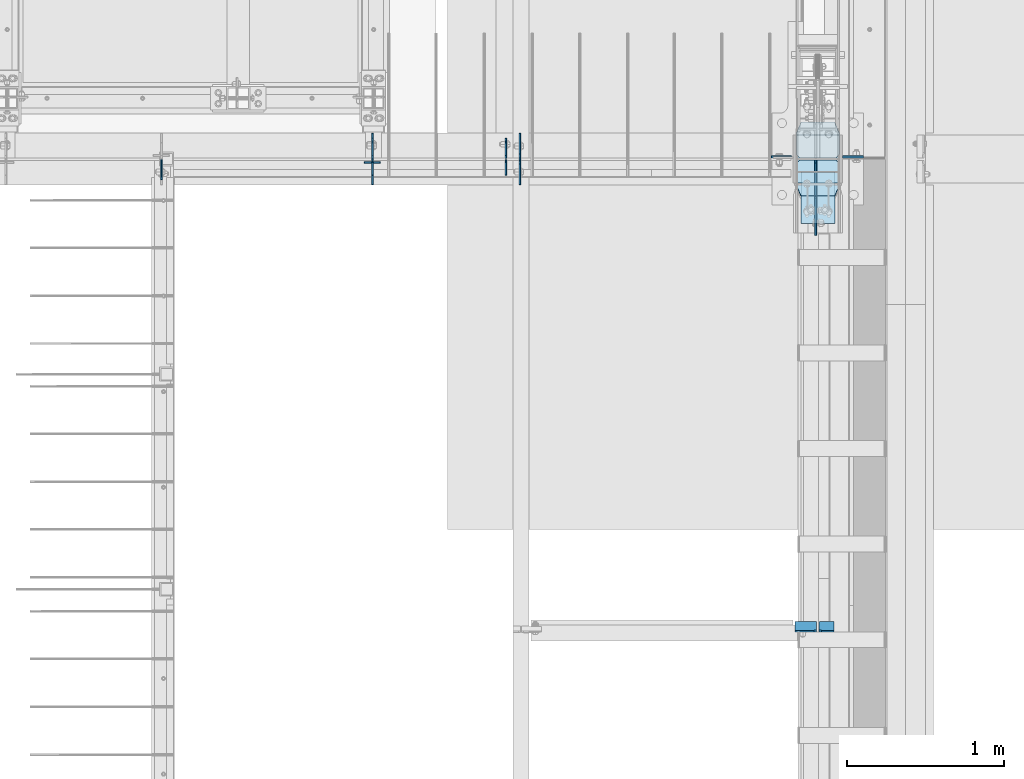
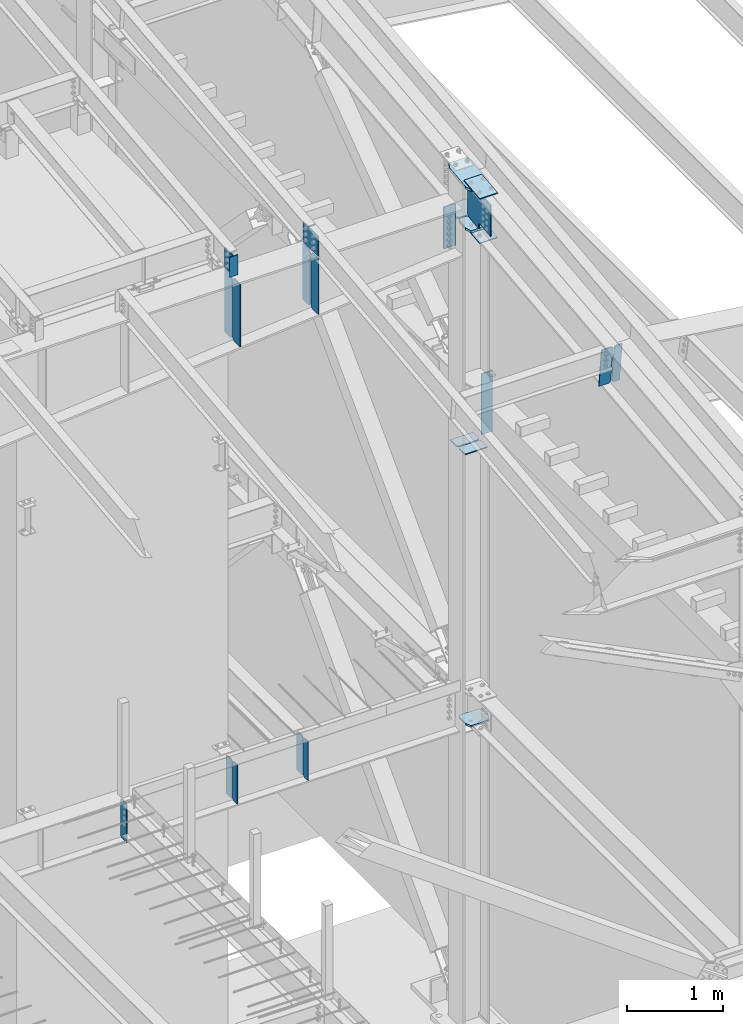
# One storey, part 1006 of 1179: 25 plates, 4 elements without a shape of their own.
"""IFC2X3 building model written with IfcOpenShell, lengths in millimetres."""

from ifc_helpers import new_model, si_unit, frame, origin_with_axes, place, context, subcontext, project, spatial, faceted_brep, material, type_object, element, aggregate, save


model = new_model("IFC2X3")

# Units and contexts
model_context = context("Model", 3, precision=1e-05, world=origin_with_axes())
body_context = subcontext(model_context, "Body", "Model", "MODEL_VIEW")
ifc_project = project(units=[si_unit("LENGTHUNIT", "METRE", prefix="MILLI"), si_unit("AREAUNIT", "SQUARE_METRE"), si_unit("VOLUMEUNIT", "CUBIC_METRE"), si_unit("MASSUNIT", "GRAM", prefix="KILO"), si_unit("TIMEUNIT", "SECOND"), si_unit("PLANEANGLEUNIT", "RADIAN"), si_unit("SOLIDANGLEUNIT", "STERADIAN"), si_unit("THERMODYNAMICTEMPERATUREUNIT", "DEGREE_CELSIUS"), si_unit("LUMINOUSINTENSITYUNIT", "LUMEN")], contexts=[model_context])

# Site, building, storey
site_placement = place(None, origin_with_axes())
site = spatial("IfcSite", under=ifc_project, at=site_placement, CompositionType="ELEMENT")
building_placement = place(site_placement, origin_with_axes())
building = spatial("IfcBuilding", under=site, at=building_placement, Name="Undefined", CompositionType="ELEMENT")
storey_placement = place(building_placement, origin_with_axes())
storey = spatial("IfcBuildingStorey", under=building, at=storey_placement, Name="Undefined", CompositionType="ELEMENT", Elevation=0.0)

# Assembly, plates
assembly_1_placement = place(storey_placement, origin_with_axes())
assembly_1 = element("IfcElementAssembly", 1, at=assembly_1_placement, inside=storey, Name="BEAM", AssemblyPlace="NOTDEFINED", PredefinedType="RIGID_FRAME")
ifc_material_1 = material(Name="STEEL/A36")
plate_type_1 = type_object("IfcPlateType", PredefinedType="NOTDEFINED")
plate_1_placement = place(assembly_1_placement, frame((22318.6620000839, 11485.5625, 3586.1625), z_axis=(0.0, 0.0, 1.0), x_axis=(0.0, 1.0, 0.0)))
plate_1 = element("IfcPlate", 2, at=plate_1_placement, type_object=plate_type_1, material=ifc_material_1, Name="PLATE", context=body_context, shape_type="Brep", body=[
    faceted_brep([(100.012000000006, -4.76250000000073, 498.475), (100.012000000006, -4.76250000000073, 496.887264521772), (100.012000000006, 4.76250000000437, 496.887264521772), (100.012000000006, 4.76250000000073, 498.475), (100.978707412354, -4.76250000000073, 492.027239348606), (100.978707412354, 4.76250000000437, 492.027239348606), (103.731660635996, -4.76250000000073, 487.907091723419), (103.731660635996, 4.76250000000437, 487.907091723419), (107.851757257211, -4.76250000000073, 485.154062167322), (107.851757257211, 4.76250000000437, 485.154062167322), (112.711764519599, -4.76250000000073, 484.187264714686), (112.711764519599, 4.76250000000437, 484.187264714686), (127.000007629395, -4.76250000000073, 484.187000000034), (127.000004873051, 4.76250000000073, 484.187000000034), (0.0, -4.76250000000073, 479.425006866455), (19.0499992370605, -4.76250000000073, 498.475006103516), (19.0499992370605, 4.76250000000073, 498.475006103516), (0.0, 4.76250000000073, 479.425006866455), (0.0, -4.76250000000073, 19.0499992370605), (0.0, 4.76250000000073, 19.0499992370605), (19.0499992370605, -4.76250000000073, 0.0), (19.0499992370605, 4.76250000000073, 0.0), (127.0, -4.76250000000073, 0.0), (127.0, 4.76250000000073, 0.0)], [[[0, 1, 2, 3]], [[4, 5, 2, 1]], [[6, 7, 5, 4]], [[8, 9, 7, 6]], [[10, 11, 9, 8]], [[12, 13, 11, 10]], [[14, 15, 16, 17]], [[18, 14, 17, 19]], [[20, 18, 19, 21]], [[22, 20, 21, 23]], [[8, 6, 4, 1, 0, 15, 14, 18, 20, 22, 12, 10]], [[16, 15, 0, 3]], [[23, 21, 19, 17, 16, 3, 2, 5, 7, 9, 11, 13]], [[22, 23, 13, 12]]]),
])
plate_2_placement = place(assembly_1_placement, frame((21467.7620000839, 11485.5625, 3586.1625), z_axis=(0.0, 0.0, 1.0), x_axis=(0.0, 1.0, 0.0)))
plate_2 = element("IfcPlate", 3, at=plate_2_placement, type_object=plate_type_1, material=ifc_material_1, Name="PLATE", context=body_context, shape_type="Brep", body=[
    faceted_brep([(100.012000000006, -4.76250000000073, 498.475), (100.012000000006, -4.76250000000073, 496.887264521772), (100.012000000006, 4.76250000000437, 496.887264521772), (100.012000000006, 4.76250000000073, 498.475), (100.978707412354, -4.76250000000073, 492.027239348606), (100.978707412354, 4.76250000000437, 492.027239348606), (103.731660635996, -4.76250000000073, 487.907091723419), (103.731660635996, 4.76250000000437, 487.907091723419), (107.851757257211, -4.76250000000073, 485.154062167322), (107.851757257211, 4.76250000000437, 485.154062167322), (112.711764519599, -4.76250000000073, 484.187264714686), (112.711764519599, 4.76250000000437, 484.187264714686), (127.000007629395, -4.76250000000073, 484.187000000034), (127.000004873051, 4.76250000000073, 484.187000000034), (0.0, -4.76250000000073, 479.425006866455), (19.0499992370605, -4.76250000000073, 498.475006103516), (19.0499992370605, 4.76250000000073, 498.475006103516), (0.0, 4.76250000000073, 479.425006866455), (0.0, -4.76250000000073, 19.0499992370605), (0.0, 4.76250000000073, 19.0499992370605), (19.0499992370605, -4.76250000000073, 0.0), (19.0499992370605, 4.76250000000073, 0.0), (127.0, -4.76250000000073, 0.0), (127.0, 4.76250000000073, 0.0)], [[[0, 1, 2, 3]], [[4, 5, 2, 1]], [[6, 7, 5, 4]], [[8, 9, 7, 6]], [[10, 11, 9, 8]], [[12, 13, 11, 10]], [[14, 15, 16, 17]], [[18, 14, 17, 19]], [[20, 18, 19, 21]], [[22, 20, 21, 23]], [[8, 6, 4, 1, 0, 15, 14, 18, 20, 22, 12, 10]], [[16, 15, 0, 3]], [[23, 21, 19, 17, 16, 3, 2, 5, 7, 9, 11, 13]], [[22, 23, 13, 12]]]),
])
plate_3_placement = place(assembly_1_placement, frame((20121.5620000839, 11476.0375, 3586.1625), z_axis=(0.0, 0.0, 1.0), x_axis=(0.0, -1.0, 0.0)))
plate_3 = element("IfcPlate", 4, at=plate_3_placement, type_object=plate_type_1, material=ifc_material_1, Name="PLATE", context=body_context, shape_type="Brep", body=[
    faceted_brep([(100.012000000006, -4.76250000000073, 498.475), (100.012000000006, -4.76250000000073, 496.887264521772), (100.012000000006, 4.76250000000437, 496.887264521772), (100.012000000006, 4.76250000000073, 498.475), (100.978707412354, -4.76250000000073, 492.027239348606), (100.978707412354, 4.76250000000437, 492.027239348606), (103.731660635996, -4.76250000000073, 487.907091723419), (103.731660635996, 4.76250000000437, 487.907091723419), (107.851757257211, -4.76250000000073, 485.154062167322), (107.851757257211, 4.76250000000437, 485.154062167322), (112.711764519599, -4.76250000000073, 484.187264714686), (112.711764519599, 4.76250000000437, 484.187264714686), (127.000007629395, -4.76250000000073, 484.187000000034), (127.000004873051, 4.76250000000073, 484.187000000034), (0.0, -4.76250000000073, 479.425006866455), (19.0499992370605, -4.76250000000073, 498.475006103516), (19.0499992370605, 4.76250000000073, 498.475006103516), (0.0, 4.76250000000073, 479.425006866455), (0.0, -4.76250000000073, 19.0499992370605), (0.0, 4.76250000000073, 19.0499992370605), (19.0499992370605, -4.76250000000073, 0.0), (19.0499992370605, 4.76250000000073, 0.0), (127.0, -4.76250000000073, 0.0), (127.0, 4.76250000000073, 0.0)], [[[0, 1, 2, 3]], [[4, 5, 2, 1]], [[6, 7, 5, 4]], [[8, 9, 7, 6]], [[10, 11, 9, 8]], [[12, 13, 11, 10]], [[14, 15, 16, 17]], [[18, 14, 17, 19]], [[20, 18, 19, 21]], [[22, 20, 21, 23]], [[8, 6, 4, 1, 0, 15, 14, 18, 20, 22, 12, 10]], [[16, 15, 0, 3]], [[23, 21, 19, 17, 16, 3, 2, 5, 7, 9, 11, 13]], [[22, 23, 13, 12]]]),
])

assembly_2_placement = place(storey_placement, origin_with_axes())
assembly_2 = element("IfcElementAssembly", 5, at=assembly_2_placement, inside=storey, Name="RAFTER BEAM", AssemblyPlace="NOTDEFINED", PredefinedType="RIGID_FRAME")
plate_type_2 = type_object("IfcPlateType", PredefinedType="NOTDEFINED")
plate_4_placement = place(assembly_2_placement, frame((21467.7625, 11645.9093353251, 10228.28385672), z_axis=(0.0, 0.0, -1.0), x_axis=(0.0, -1.0, 0.0)))
plate_4 = element("IfcPlate", 6, at=plate_4_placement, type_object=plate_type_2, material=ifc_material_1, Name="PLATE", context=body_context, shape_type="Brep", body=[
    faceted_brep([(0.0, -4.76249999999709, 0.0), (-1.85116005013697e-06, -4.76250000000073, 795.843735329721), (-1.85116005013697e-06, 4.76250000000073, 795.843735329721), (0.0, 4.76249999999709, 0.0), (131.762498530312, -4.76250000000073, 795.843735649332), (131.762498530312, 4.76250000000073, 795.843735649332), (157.162498207919, -4.76250000000073, 770.443736092411), (157.162498207919, 4.76250000000073, 770.443736092411), (157.162499942613, -4.76250000000073, 25.3999996182793), (157.162499942613, 4.76250000000073, 25.3999996182793), (131.762500381465, -4.76250000000073, -2.09183781407773e-10), (131.762500381465, 4.76250000000073, -2.09183781407773e-10)], [[[0, 1, 2, 3]], [[1, 4, 5, 2]], [[4, 6, 7, 5]], [[6, 8, 9, 7]], [[8, 10, 11, 9]], [[10, 0, 3, 11]], [[5, 7, 9, 11, 3, 2]], [[10, 8, 6, 4, 1, 0]]]),
])
plate_5_placement = place(assembly_2_placement, frame((22407.5625, 11645.9093353251, 10228.28385672), z_axis=(0.0, 0.0, -1.0), x_axis=(0.0, -1.0, 0.0)))
plate_5 = element("IfcPlate", 7, at=plate_5_placement, type_object=plate_type_2, material=ifc_material_1, Name="PLATE", context=body_context, shape_type="Brep", body=[
    faceted_brep([(0.0, -4.76249999999709, 0.0), (-1.68650149134919e-06, -4.76250000000073, 713.502596248929), (-1.68650149134919e-06, 4.76250000000073, 713.502596248929), (0.0, 4.76249999999709, 0.0), (131.762498694967, -4.76250000000073, 713.50259656854), (131.762498694967, 4.76250000000073, 713.50259656854), (157.162498373538, -4.76250000000073, 688.102597011619), (157.162498373538, 4.76250000000073, 688.102597011619), (157.162499942613, -4.76250000000073, 25.3999996182793), (157.162499942613, 4.76250000000073, 25.3999996182793), (131.762500381465, -4.76250000000073, -2.09183781407773e-10), (131.762500381465, 4.76250000000073, -2.09183781407773e-10)], [[[0, 1, 2, 3]], [[1, 4, 5, 2]], [[4, 6, 7, 5]], [[6, 8, 9, 7]], [[8, 10, 11, 9]], [[10, 0, 3, 11]], [[5, 7, 9, 11, 3, 2]], [[10, 8, 6, 4, 1, 0]]]),
])
plate_6_placement = place(assembly_2_placement, frame((21467.7625, 11315.7093353614, 10228.28385672), z_axis=(0.0, 0.0, -1.0), x_axis=(0.0, 1.0, 0.0)))
plate_6 = element("IfcPlate", 8, at=plate_6_placement, type_object=plate_type_2, material=ifc_material_1, Name="PLATE", context=body_context, shape_type="Brep", body=[
    faceted_brep([(0.0, -4.76249999999709, 0.0), (-1.85116005013697e-06, -4.76250000000073, 795.843735329721), (-1.85116005013697e-06, 4.76250000000073, 795.843735329721), (0.0, 4.76249999999709, 0.0), (131.762498530312, -4.76250000000073, 795.843735649332), (131.762498530312, 4.76250000000073, 795.843735649332), (157.162498207919, -4.76250000000073, 770.443736092411), (157.162498207919, 4.76250000000073, 770.443736092411), (157.162499942613, -4.76250000000073, 25.3999996182793), (157.162499942613, 4.76250000000073, 25.3999996182793), (131.762500381465, -4.76250000000073, -2.09183781407773e-10), (131.762500381465, 4.76250000000073, -2.09183781407773e-10)], [[[0, 1, 2, 3]], [[1, 4, 5, 2]], [[4, 6, 7, 5]], [[6, 8, 9, 7]], [[8, 10, 11, 9]], [[10, 0, 3, 11]], [[5, 7, 9, 11, 3, 2]], [[10, 8, 6, 4, 1, 0]]]),
])
plate_7_placement = place(assembly_2_placement, frame((22407.5625, 11315.7093353614, 10228.28385672), z_axis=(0.0, 0.0, -1.0), x_axis=(0.0, 1.0, 0.0)))
plate_7 = element("IfcPlate", 9, at=plate_7_placement, type_object=plate_type_2, material=ifc_material_1, Name="PLATE", context=body_context, shape_type="Brep", body=[
    faceted_brep([(0.0, -4.76249999999709, 0.0), (-1.68650149134919e-06, -4.76250000000073, 713.502596248929), (-1.68650149134919e-06, 4.76250000000073, 713.502596248929), (0.0, 4.76249999999709, 0.0), (131.762498694967, -4.76250000000073, 713.50259656854), (131.762498694967, 4.76250000000073, 713.50259656854), (157.162498373538, -4.76250000000073, 688.102597011619), (157.162498373538, 4.76250000000073, 688.102597011619), (157.162499942613, -4.76250000000073, 25.3999996182793), (157.162499942613, 4.76250000000073, 25.3999996182793), (131.762500381465, -4.76250000000073, -2.09183781407773e-10), (131.762500381465, 4.76250000000073, -2.09183781407773e-10)], [[[0, 1, 2, 3]], [[1, 4, 5, 2]], [[4, 6, 7, 5]], [[6, 8, 9, 7]], [[8, 10, 11, 9]], [[10, 0, 3, 11]], [[5, 7, 9, 11, 3, 2]], [[10, 8, 6, 4, 1, 0]]]),
])

assembly_3_placement = place(storey_placement, origin_with_axes())
assembly_3 = element("IfcElementAssembly", 10, at=assembly_3_placement, inside=storey, Name="BEAM", AssemblyPlace="NOTDEFINED", PredefinedType="RIGID_FRAME")
plate_type_3 = type_object("IfcPlateType", PredefinedType="NOTDEFINED")
plate_8_placement = place(assembly_3_placement, frame((24314.9437499989, 8525.70288097316, 9683.06425336899), z_axis=(0.0, -0.112284087038017, 0.993676146336441), x_axis=(1.0, 0.0, 0.0)))
plate_8 = element("IfcPlate", 11, at=plate_8_placement, type_object=plate_type_3, material=ifc_material_1, Name="PLATE", context=body_context, shape_type="Brep", body=[
    faceted_brep([(0.0, -6.34999999998763, 17.4624996185248), (0.0, -6.34999999979846, 481.012500380079), (0.0, 6.350000000195, 481.012500380073), (0.0, 6.35000000000582, 17.4624996185175), (17.4624996185303, -6.349999999793, 498.474999998598), (17.4624996185303, 6.35000000020045, 498.474999998592), (95.25, -6.349999999793, 498.474999998598), (95.25, 6.35000000020045, 498.474999998592), (95.25, -6.34999999999309, 1.81898940354586e-12), (95.25, 6.34999999999854, -1.81898940354586e-12), (17.4624996185303, -6.34999999999309, 1.81898940354586e-12), (17.4624996185303, 6.34999999999854, -1.81898940354586e-12)], [[[0, 1, 2, 3]], [[1, 4, 5, 2]], [[4, 6, 7, 5]], [[6, 8, 9, 7]], [[8, 10, 11, 9]], [[10, 0, 3, 11]], [[5, 7, 9, 11, 3, 2]], [[10, 8, 6, 4, 1, 0]]]),
])
plate_type_4 = type_object("IfcPlateType", PredefinedType="NOTDEFINED")
plate_9_placement = place(assembly_3_placement, frame((24300.6562383085, 8469.73181834931, 10178.3879431662), z_axis=(-1.0, 0.0, 0.0), x_axis=(0.0, 0.112284087038014, -0.993676146336441)))
plate_9 = element("IfcPlate", 12, at=plate_9_placement, type_object=plate_type_4, material=ifc_material_1, Name="PLATE", context=body_context, shape_type="Brep", body=[
    faceted_brep([(0.0, -6.34999999998763, 17.4624996185248), (0.0, -6.34999999999673, 139.700000000001), (-3.63797880709171e-12, 6.34999999999491, 139.700000000001), (0.0, 6.35000000000582, 17.4624996185175), (498.474999999775, -6.34999999979482, 139.700000000001), (498.474999999769, 6.35000000019681, 139.700000000001), (498.474999999775, -6.34999999979482, 17.4624996185303), (498.474999999769, 6.35000000019681, 17.4624996185303), (481.012500381255, -6.34999999980209, 0.0), (481.01250038125, 6.35000000019136, 0.0), (17.4624996185303, -6.34999999999309, 1.81898940354586e-12), (17.4624996185303, 6.34999999999854, -1.81898940354586e-12)], [[[0, 1, 2, 3]], [[1, 4, 5, 2]], [[4, 6, 7, 5]], [[6, 8, 9, 7]], [[8, 10, 11, 9]], [[10, 0, 3, 11]], [[5, 7, 9, 11, 3, 2]], [[10, 8, 6, 4, 1, 0]]]),
])
aggregate(assembly_3, [plate_8, plate_9])

assembly_4_placement = place(storey_placement, origin_with_axes())
assembly_4 = element("IfcElementAssembly", 13, at=assembly_4_placement, inside=storey, Name="COLUMN", AssemblyPlace="NOTDEFINED", PredefinedType="RIGID_FRAME")
plate_10_placement = place(assembly_4_placement, frame((24010.9375000232, 11495.0968353614, 10213.996358365), z_axis=(0.0, 0.0, -1.0), x_axis=(1.0, 0.0, 0.0)))
plate_10 = element("IfcPlate", 14, at=plate_10_placement, type_object=plate_type_4, material=ifc_material_1, Name="PLATE", context=body_context, shape_type="Brep", body=[
    faceted_brep([(127.000004873051, -6.34999999999854, 0.0), (139.699999999997, 6.35000000000036, 0.0), (139.700000000001, 6.35000000000036, 533.4), (127.0, -6.35000000000036, 533.4), (0.0, -6.34999999999854, 0.0), (0.0, -6.35000000000036, 533.4), (0.0, 6.35000000000036, 533.4), (0.0, 6.34999999999854, 0.0)], [[[0, 1, 2, 3]], [[4, 5, 6, 7]], [[6, 5, 3, 2]], [[4, 7, 1, 0]], [[2, 1, 7, 6]], [[5, 4, 0, 3]]]),
])
ifc_material_2 = material(Name="STEEL/A572-GR.50")
plate_type_5 = type_object("IfcPlateType", PredefinedType="NOTDEFINED")
plate_11_placement = place(assembly_4_placement, frame((24171.2749999998, 11244.1139130949, 10503.0809010539), z_axis=(1.0, 0.0, 0.0), x_axis=(0.0, 0.993683229349742, 0.112221387039499)))
plate_11 = element("IfcPlate", 15, at=plate_11_placement, type_object=plate_type_5, material=ifc_material_2, Name="PLATE", context=body_context, shape_type="Brep", body=[
    faceted_brep([(404.009737741189, -14.2874999996602, 8.31619217933621e-11), (71.43750000002, -14.287499999984, 2.90469870378729e-11), (71.4375000000155, 14.2874999999949, 2.90469870378729e-11), (404.009737741166, 14.2875000003405, 8.31619217933621e-11), (477.034739267168, 14.2875000004005, 30.162500381568), (473.810043726306, -14.287499999602, 28.8305609300143), (477.034739268025, 14.2875000004024, 242.887499623284), (473.810043726306, -14.287499999602, 244.219439075195), (404.009737742264, 14.2875000003405, 273.05000000474), (404.00973774229, -14.2874999996602, 273.05000000474), (71.4375000016116, -14.2874999999858, 273.049999999798), (71.4375000016071, 14.2874999999967, 273.049999999798), (4.20644072178584, 14.2875000000058, 244.663552394444), (0.979329666730337, -14.2874999999967, 243.30099437618), (0.979329666730337, -14.2874999999967, 29.7490056281208), (4.20644072178584, 14.2875000000058, 28.3864476098539)], [[[0, 1, 2, 3]], [[0, 3, 4, 5]], [[5, 4, 6, 7]], [[8, 9, 7, 6]], [[10, 9, 8, 11]], [[10, 11, 12, 13]], [[1, 0, 5, 7, 9, 10, 13, 14]], [[2, 1, 14, 15]], [[11, 8, 6, 4, 3, 2, 15, 12]], [[14, 13, 12, 15]]]),
])

# Plate
plate_type_6 = type_object("IfcPlateType", PredefinedType="NOTDEFINED")
plate_12_placement = place(assembly_2_placement, frame((21467.7625, 11639.5500004734, 10252.0963567621), z_axis=(0.0, -1.0, 0.0), x_axis=(0.0, 0.0, 1.0)))
plate_12 = element("IfcPlate", 16, at=plate_12_placement, type_object=plate_type_6, material=ifc_material_1, Name="PLATE", context=body_context, shape_type="Brep", body=[
    faceted_brep([(0.0, -4.76249999999709, 0.0), (3.08111339109018e-07, -4.76250000000073, 177.800000293439), (3.08111339109018e-07, 4.76250000000073, 177.800000293439), (0.0, 4.76249999999709, 0.0), (254.0, -4.76250000000073, 177.799999999999), (254.0, 4.76250000000073, 177.799999999999), (254.0, -4.76250000000073, 0.0), (254.0, 4.76250000000073, 0.0)], [[[0, 1, 2, 3]], [[1, 4, 5, 2]], [[4, 6, 7, 5]], [[6, 0, 3, 7]], [[5, 7, 3, 2]], [[6, 4, 1, 0]]]),
])

plate_type_7 = type_object("IfcPlateType", PredefinedType="NOTDEFINED")
plate_13_placement = place(assembly_1_placement, frame((22318.6620000839, 11476.0375, 3586.1625), z_axis=(0.0, 0.0, 1.0), x_axis=(0.0, -1.0, 0.0)))
plate_13 = element("IfcPlate", 17, at=plate_13_placement, type_object=plate_type_7, material=ifc_material_1, Name="PLATE", context=body_context, shape_type="Brep", body=[
    faceted_brep([(0.0, -4.76250000000073, 19.0499992370605), (0.0, -4.76250000000073, 479.425006866455), (0.0, 4.76250000000073, 479.425006866455), (0.0, 4.76250000000073, 19.0499992370605), (19.0499992370605, -4.76250000000073, 498.475006103516), (19.0499992370605, 4.76250000000073, 498.475006103516), (98.4249999999993, -4.76250000000073, 498.475), (98.4249999999993, 4.76250000000073, 498.475), (98.4249999999993, -4.76250000000073, 0.0), (98.4249999999993, 4.76250000000073, 0.0), (19.0499992370605, -4.76250000000073, 0.0), (19.0499992370605, 4.76250000000073, 0.0)], [[[0, 1, 2, 3]], [[1, 4, 5, 2]], [[4, 6, 7, 5]], [[6, 8, 9, 7]], [[8, 10, 11, 9]], [[10, 0, 3, 11]], [[5, 7, 9, 11, 3, 2]], [[10, 8, 6, 4, 1, 0]]]),
])

plate_14_placement = place(assembly_1_placement, frame((21467.7620000839, 11476.0375, 3586.1625), z_axis=(0.0, 0.0, 1.0), x_axis=(0.0, -1.0, 0.0)))
plate_14 = element("IfcPlate", 18, at=plate_14_placement, type_object=plate_type_7, material=ifc_material_1, Name="PLATE", context=body_context, shape_type="Brep", body=[
    faceted_brep([(0.0, -4.76250000000073, 19.0499992370605), (0.0, -4.76250000000073, 479.425006866455), (0.0, 4.76250000000073, 479.425006866455), (0.0, 4.76250000000073, 19.0499992370605), (19.0499992370605, -4.76250000000073, 498.475006103516), (19.0499992370605, 4.76250000000073, 498.475006103516), (98.4249999999993, -4.76250000000073, 498.475), (98.4249999999993, 4.76250000000073, 498.475), (98.4249999999993, -4.76250000000073, 0.0), (98.4249999999993, 4.76250000000073, 0.0), (19.0499992370605, -4.76250000000073, 0.0), (19.0499992370605, 4.76250000000073, 0.0)], [[[0, 1, 2, 3]], [[1, 4, 5, 2]], [[4, 6, 7, 5]], [[6, 8, 9, 7]], [[8, 10, 11, 9]], [[10, 0, 3, 11]], [[5, 7, 9, 11, 3, 2]], [[10, 8, 6, 4, 1, 0]]]),
])

aggregate(assembly_1, [plate_13, plate_1, plate_14, plate_2, plate_3])

plate_type_8 = type_object("IfcPlateType", PredefinedType="NOTDEFINED")
plate_15_placement = place(assembly_4_placement, frame((24171.275, 11245.85, 3697.2875), z_axis=(1.0, 0.0, 0.0), x_axis=(0.0, 1.0, 0.0)))
plate_15 = element("IfcPlate", 19, at=plate_15_placement, type_object=plate_type_8, material=ifc_material_2, Name="PLATE", context=body_context, shape_type="Brep", body=[
    faceted_brep([(0.0, -11.1125000000002, 247.650000381473), (63.5, -11.1125000000002, 273.050000000003), (63.5, 11.1125000000002, 273.050000000003), (0.0, 11.1125000000002, 247.650000381473), (63.5, -11.1125000000002, 0.0), (0.0, -11.1125000000002, 25.3999996185303), (0.0, 11.1125000000002, 25.3999996185303), (63.5, 11.1125000000002, 0.0), (206.374999618529, -11.1125000000002, 0.0), (206.374999618529, 11.1125000000002, 0.0), (228.599999999999, -11.1125000000002, 22.2250003814697), (228.599999999999, 11.1125000000002, 22.2250003814697), (228.599999999999, -11.1125000000002, 250.824999618533), (228.599999999999, 11.1125000000002, 250.824999618533), (206.374999618529, -11.1125000000002, 273.050000000003), (206.374999618529, 11.1125000000002, 273.050000000003)], [[[0, 1, 2, 3]], [[4, 5, 6, 7]], [[8, 4, 7, 9]], [[10, 8, 9, 11]], [[12, 10, 11, 13]], [[14, 12, 13, 15]], [[4, 8, 10, 12, 14, 1, 0, 5]], [[5, 0, 3, 6]], [[2, 15, 13, 11, 9, 7, 6, 3]], [[1, 14, 15, 2]]]),
])

plate_type_9 = type_object("IfcPlateType", PredefinedType="NOTDEFINED")
plate_16_placement = place(assembly_4_placement, frame((24444.325, 11474.45, 7110.16703089335), z_axis=(-1.0, 0.0, 0.0), x_axis=(0.0, -1.0, 0.0)))
plate_16 = element("IfcPlate", 20, at=plate_16_placement, type_object=plate_type_9, material=ifc_material_1, Name="PLATE", context=body_context, shape_type="Brep", body=[
    faceted_brep([(0.0, -6.34999999999854, 22.2250003814697), (0.0, -6.35000000000036, 250.82499961853), (0.0, 6.35000000000036, 250.82499961853), (0.0, 6.34999999999854, 22.2250003814697), (22.2250003814697, -6.35000000000036, 273.05), (22.2250003814697, 6.35000000000036, 273.05), (146.050003051758, -6.35000000000036, 273.049987792969), (146.050003051758, 6.35000000000036, 273.049987792969), (146.050003051758, -6.35000000000036, 0.0), (146.050003051758, 6.35000000000036, 0.0), (22.2250003814697, -6.34999999999854, 0.0), (22.2250003814697, 6.34999999999854, 0.0)], [[[0, 1, 2, 3]], [[1, 4, 5, 2]], [[4, 6, 7, 5]], [[6, 8, 9, 7]], [[8, 10, 11, 9]], [[10, 0, 3, 11]], [[5, 7, 9, 11, 3, 2]], [[10, 8, 6, 4, 1, 0]]]),
])

plate_17_placement = place(assembly_4_placement, frame((24444.325, 11633.2, 7110.16703089335), z_axis=(-1.0, 0.0, 0.0), x_axis=(0.0, -1.0, 0.0)))
plate_17 = element("IfcPlate", 21, at=plate_17_placement, type_object=plate_type_9, material=ifc_material_1, Name="PLATE", context=body_context, shape_type="Brep", body=[
    faceted_brep([(0.0, -6.34999999999854, 0.0), (0.0, -6.34999999999991, 273.05), (0.0, 6.34999999999991, 273.05), (0.0, 6.34999999999854, 0.0), (123.824999618599, -6.34999999999991, 273.05), (123.824999618599, 6.34999999999991, 273.05), (146.050000000068, -6.34999999999991, 250.82499961853), (146.050000000068, 6.34999999999991, 250.82499961853), (146.050000000068, -6.34999999999991, 22.2250003814697), (146.050000000068, 6.34999999999991, 22.2250003814697), (123.824999618599, -6.34999999999991, 0.0), (123.824999618599, 6.34999999999991, 0.0)], [[[0, 1, 2, 3]], [[1, 4, 5, 2]], [[4, 6, 7, 5]], [[6, 8, 9, 7]], [[8, 10, 11, 9]], [[10, 0, 3, 11]], [[5, 7, 9, 11, 3, 2]], [[10, 8, 6, 4, 1, 0]]]),
])

plate_type_10 = type_object("IfcPlateType", PredefinedType="NOTDEFINED")
plate_18_placement = place(assembly_4_placement, frame((24464.9625, 11495.0875, 7936.73589801267), z_axis=(1.0, 0.0, 0.0), x_axis=(0.0, 0.0, -1.0)))
plate_18 = element("IfcPlate", 22, at=plate_18_placement, type_object=plate_type_10, material=ifc_material_1, Name="PLATE", context=body_context, shape_type="Brep", body=[
    faceted_brep([(0.0, -6.34999999999854, 0.0), (0.0, -6.34999999999854, 133.350000000002), (0.0, 6.34999999999854, 133.350000000002), (0.0, 6.34999999999854, 0.0), (774.700012207031, -6.35000000000036, 133.350006103516), (774.700012207031, 6.35000000000036, 133.350006103516), (774.700012207031, -6.35000000000036, 0.0), (774.700012207031, 6.35000000000036, 0.0)], [[[0, 1, 2, 3]], [[1, 4, 5, 2]], [[4, 6, 7, 5]], [[6, 0, 3, 7]], [[5, 7, 3, 2]], [[6, 4, 1, 0]]]),
])

plate_type_11 = type_object("IfcPlateType", PredefinedType="NOTDEFINED")
plate_19_placement = place(assembly_4_placement, frame((24199.8500030684, 11069.8882512744, 10504.1329294643), z_axis=(1.0, 0.0, 0.0), x_axis=(0.0, 0.993676146336441, 0.112284087038017)))
plate_19 = element("IfcPlate", 23, at=plate_19_placement, type_object=plate_type_11, material=ifc_material_2, Name="PLATE", context=body_context, shape_type="Brep", body=[
    faceted_brep([(0.0, -6.34999999999854, 0.0), (0.0, -6.350000000004, 215.899993896484), (0.0, 6.35000000000582, 215.899993896484), (0.0, 6.34999999999854, 0.0), (330.200000001782, -6.34999999994034, 215.899993896483), (330.200000001782, 6.35000000006767, 215.899993896483), (330.200000001782, -6.34999999994034, -1.47792889038101e-12), (330.200000001782, 6.35000000006767, -1.47792889038101e-12)], [[[0, 1, 2, 3]], [[1, 4, 5, 2]], [[4, 6, 7, 5]], [[6, 0, 3, 7]], [[5, 7, 3, 2]], [[6, 4, 1, 0]]]),
])

plate_20_placement = place(assembly_4_placement, frame((24199.8500030415, 11070.5392709459, 9938.67533066403), z_axis=(1.0, 0.0, 0.0), x_axis=(0.0, 0.993676146336441, 0.112284087038017)))
plate_20 = element("IfcPlate", 24, at=plate_20_placement, type_object=plate_type_11, material=ifc_material_2, Name="PLATE", context=body_context, shape_type="Brep", body=[
    faceted_brep([(0.0, -6.34999999999854, 0.0), (0.0, -6.350000000004, 215.899993896484), (0.0, 6.35000000000582, 215.899993896484), (0.0, 6.34999999999854, 0.0), (330.200000001782, -6.34999999994034, 215.899993896483), (330.200000001782, 6.35000000006767, 215.899993896483), (330.200000001782, -6.34999999994034, -1.47792889038101e-12), (330.200000001782, 6.35000000006767, -1.47792889038101e-12)], [[[0, 1, 2, 3]], [[1, 4, 5, 2]], [[4, 6, 7, 5]], [[6, 0, 3, 7]], [[5, 7, 3, 2]], [[6, 4, 1, 0]]]),
])

plate_type_12 = type_object("IfcPlateType", PredefinedType="NOTDEFINED")
plate_21_placement = place(assembly_4_placement, frame((24171.2750000005, 11244.1139131727, 9978.96694756484), z_axis=(1.0, 0.0, 0.0), x_axis=(0.0, 0.993676146336441, 0.112284087038017)))
plate_21 = element("IfcPlate", 25, at=plate_21_placement, type_object=plate_type_12, material=ifc_material_2, Name="PLATE", context=body_context, shape_type="Brep", body=[
    faceted_brep([(207.962499617965, -14.2875000000749, 8.87325768417213e-11), (71.43750000002, -14.287499999984, 2.90469870378729e-11), (71.4375000000155, 14.2874999999949, 2.90469870378729e-11), (207.962499617975, 14.2874999999094, 8.87325768417213e-11), (230.187499999511, -14.287500000084, 22.225000381568), (230.187499999523, 14.2874999999003, 22.225000381568), (230.187500000431, -14.2875000000822, 250.824999623284), (230.187500000442, 14.2874999998985, 250.824999623284), (207.962499619063, -14.2875000000731, 273.050000004745), (207.962499619074, 14.2874999999112, 273.050000004745), (71.4375000016116, -14.2874999999858, 273.049999999798), (71.4375000016071, 14.2874999999967, 273.049999999798), (4.20737223302058, 14.2874999999931, 244.663945699182), (0.978435120117865, -14.2874999999894, 243.300616678719), (0.978435120117865, -14.2874999999894, 29.7493833255772), (4.20737223302058, 14.2874999999931, 28.3860543051127)], [[[0, 1, 2, 3]], [[4, 0, 3, 5]], [[6, 4, 5, 7]], [[8, 6, 7, 9]], [[10, 8, 9, 11]], [[10, 11, 12, 13]], [[1, 0, 4, 6, 8, 10, 13, 14]], [[2, 1, 14, 15]], [[11, 9, 7, 5, 3, 2, 15, 12]], [[14, 13, 12, 15]]]),
])

plate_type_13 = type_object("IfcPlateType", PredefinedType="NOTDEFINED")
plate_22_placement = place(assembly_4_placement, frame((24444.325, 11719.0635477105, 10032.6356265712), z_axis=(-1.0, 0.0, 0.0), x_axis=(0.0, -0.993676146336441, -0.112284087038017)))
plate_22 = element("IfcPlate", 26, at=plate_22_placement, type_object=plate_type_13, material=ifc_material_2, Name="PLATE", context=body_context, shape_type="Brep", body=[
    faceted_brep([(209.549999618157, -14.287499999904, 0.0), (73.0250015258425, -14.2874999999603, 0.0), (73.0250015258298, 14.2875000000258, 0.0), (209.549999618144, 14.2875000000804, 0.0), (231.774999999612, -14.2874999998949, 22.2250003814697), (231.774999999603, 14.2875000000895, 22.2250003814697), (231.774999999612, -14.2874999998949, 250.824999618533), (231.774999999603, 14.2875000000895, 250.824999618533), (209.549999618157, -14.287499999904, 273.050000000002), (209.549999618144, 14.2875000000804, 273.050000000002), (73.0250015258425, -14.2874999999603, 273.049999999998), (73.0250015258298, 14.2875000000258, 273.049999999998), (4.15974163581814, -14.2874999999876, 244.605653758279), (4.15974163581814, -14.2874999999876, 28.4443462417166), (0.930804522917242, 14.2874999999949, 29.7780376469105), (0.930804522917242, 14.2874999999949, 243.271962353085)], [[[0, 1, 2, 3]], [[4, 0, 3, 5]], [[6, 4, 5, 7]], [[8, 6, 7, 9]], [[10, 8, 9, 11]], [[1, 0, 4, 6, 8, 10, 12, 13]], [[2, 1, 13, 14]], [[11, 9, 7, 5, 3, 2, 14, 15]], [[10, 11, 15, 12]], [[14, 13, 12, 15]]]),
])

plate_type_14 = type_object("IfcPlateType", PredefinedType="NOTDEFINED")
plate_23_placement = place(assembly_4_placement, frame((24294.30625, 11474.4499999768, 10038.0276509383), z_axis=(0.0, -0.743858433013958, 0.668337214012522), x_axis=(0.0, -0.668337214012522, -0.743858433013957)))
plate_23 = element("IfcPlate", 27, at=plate_23_placement, type_object=plate_type_14, material=ifc_material_2, Name="PLATE", context=body_context, shape_type="Brep", body=[
    faceted_brep([(0.0, 6.34999999999854, 0.0), (0.0, -6.34999999999854, 0.0), (-340.417795237816, -6.35000000000002, 305.856424769073), (-340.417795237816, 6.35000000000002, 305.856424769073), (28.5035613092805, -6.35000000000002, -1.04591890703887e-11), (28.5035613092805, 6.35000000000002, -1.04591890703887e-11), (185.535041792471, -6.35000000000002, 139.488379402524), (185.535041792471, 6.35000000000002, 139.488379402524), (150.391206739107, -6.35000000000002, 171.064189752232), (150.391206739107, 6.35000000000002, 171.064189752232), (145.102749755571, -6.35000000000002, 177.732630246504), (145.102749755571, 6.35000000000002, 177.732630246504), (142.314026896069, -6.35000000000002, 185.773706089029), (142.314026896069, 6.35000000000002, 185.773706089029), (142.338144349787, -6.35000000000002, 194.28459877081), (142.338144349787, 6.35000000000002, 194.28459877081), (145.172394309466, -6.35000000000002, 202.30974070466), (145.172394309466, 6.35000000000002, 202.30974070466), (150.498558992693, -6.35000000000002, 208.948102374491), (150.498558992693, 6.35000000000002, 208.948102374491), (319.572465694362, -6.35000000000002, 359.133576332748), (319.572465694362, 6.35000000000002, 359.133576332748), (24.8516291671876, -6.35000000000002, 623.932487042394), (24.8516291671876, 6.35000000000002, 623.932487042394), (-148.513946545472, -6.35000000000002, 469.934796538949), (-148.513946545472, 6.35000000000002, 469.934796538949), (-156.393362644572, -6.35000000000002, 465.168486686387), (-156.393362644572, 6.35000000000002, 465.168486686387), (-165.454335371476, -6.35000000000002, 463.524807607098), (-165.454335371476, 6.35000000000002, 463.524807607098), (-174.505847216309, -6.35000000000002, 465.219812325748), (-174.505847216309, 6.35000000000002, 465.219812325748), (-182.358124252696, -6.35000000000002, 470.030701330617), (-182.358124252696, 6.35000000000002, 470.030701330617), (-183.234586416478, -6.34999999999854, 470.818179504989), (-340.34666495827, -6.34999999999854, 331.240457078814), (-340.34666495827, 6.34999999999854, 331.240457078814), (-183.234586416478, 6.34999999999854, 470.818179504989)], [[[0, 1, 2, 3]], [[4, 1, 0, 5]], [[6, 4, 5, 7]], [[8, 6, 7, 9]], [[10, 8, 9, 11]], [[12, 10, 11, 13]], [[14, 12, 13, 15]], [[16, 14, 15, 17]], [[18, 16, 17, 19]], [[20, 18, 19, 21]], [[22, 20, 21, 23]], [[24, 22, 23, 25]], [[26, 24, 25, 27]], [[28, 26, 27, 29]], [[30, 28, 29, 31]], [[32, 30, 31, 33]], [[2, 1, 4, 6, 8, 10, 12, 14, 16, 18, 20, 22, 24, 26, 28, 30, 32, 34, 35]], [[3, 2, 35, 36]], [[33, 31, 29, 27, 25, 23, 21, 19, 17, 15, 13, 11, 9, 7, 5, 0, 3, 36, 37]], [[32, 33, 37, 34]], [[36, 35, 34, 37]]]),
])

aggregate(assembly_4, [plate_19, plate_11, plate_20, plate_22, plate_21, plate_23, plate_10, plate_16, plate_17, plate_18, plate_15])

plate_type_15 = type_object("IfcPlateType", PredefinedType="NOTDEFINED")
plate_24_placement = place(assembly_2_placement, frame((21416.9624995332, 11456.9875059172, 10506.0963567669), z_axis=(0.0, 0.0, -1.0), x_axis=(1.0, 0.0, 0.0)))
plate_24 = element("IfcPlate", 28, at=plate_24_placement, type_object=plate_type_15, material=ifc_material_1, Name="PLATE", context=body_context, shape_type="Brep", body=[
    faceted_brep([(0.0, -4.76249999999709, 0.0), (-3.63797880709171e-12, -4.76249999988795, 253.999999691892), (0.0, 4.7625000001135, 253.99999969189), (0.0, 4.76249999999709, 0.0), (101.600000000017, -4.76249999989886, 254.00000000006), (101.600000000017, 4.76250000010259, 254.000000000058), (101.600000000017, -4.76250000001164, 6.00266503170133e-11), (101.600000000017, 4.76249999998981, 5.82076609134674e-11)], [[[0, 1, 2, 3]], [[1, 4, 5, 2]], [[4, 6, 7, 5]], [[6, 0, 3, 7]], [[5, 7, 3, 2]], [[6, 4, 1, 0]]]),
])

plate_type_16 = type_object("IfcPlateType", PredefinedType="NOTDEFINED")
plate_25_placement = place(assembly_2_placement, frame((22407.5625, 11639.5500004736, 10252.0963567619), z_axis=(0.0, -1.0, 0.0), x_axis=(0.0, 0.0, 1.0)))
plate_25 = element("IfcPlate", 29, at=plate_25_placement, type_object=plate_type_16, material=ifc_material_1, Name="PLATE", context=body_context, shape_type="Brep", body=[
    faceted_brep([(0.0, -4.76249999999709, 0.0), (8.00355337560177e-11, -4.7624999999889, 317.49999188591), (6.91215973347425e-11, 4.76250000001255, 317.49999188591), (0.0, 4.76249999999709, 0.0), (254.0, -4.76249999999982, 317.5), (254.0, 4.76249999999982, 317.5), (254.0, -4.76250000000073, 0.0), (254.0, 4.76250000000073, 0.0)], [[[0, 1, 2, 3]], [[1, 4, 5, 2]], [[4, 6, 7, 5]], [[6, 0, 3, 7]], [[5, 7, 3, 2]], [[6, 4, 1, 0]]]),
])

aggregate(assembly_2, [plate_4, plate_5, plate_6, plate_7, plate_24, plate_12, plate_25])

save(model, "model.ifc")
